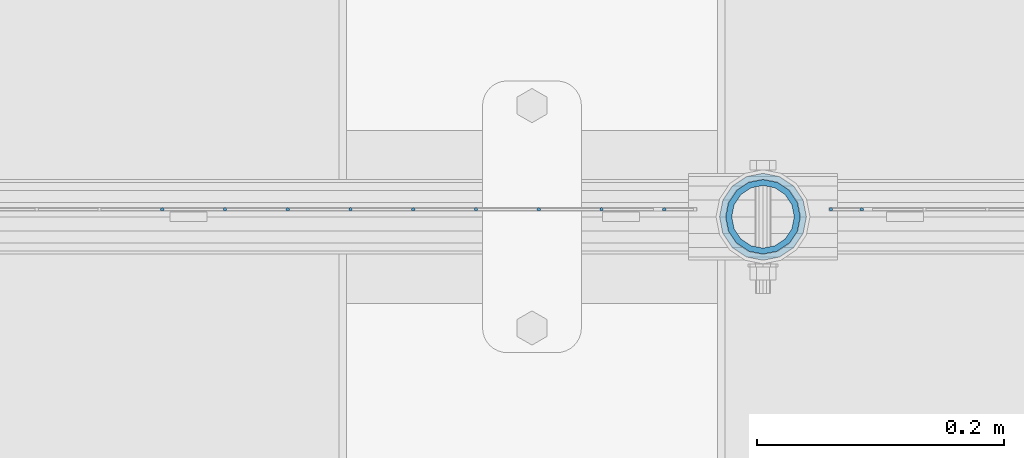
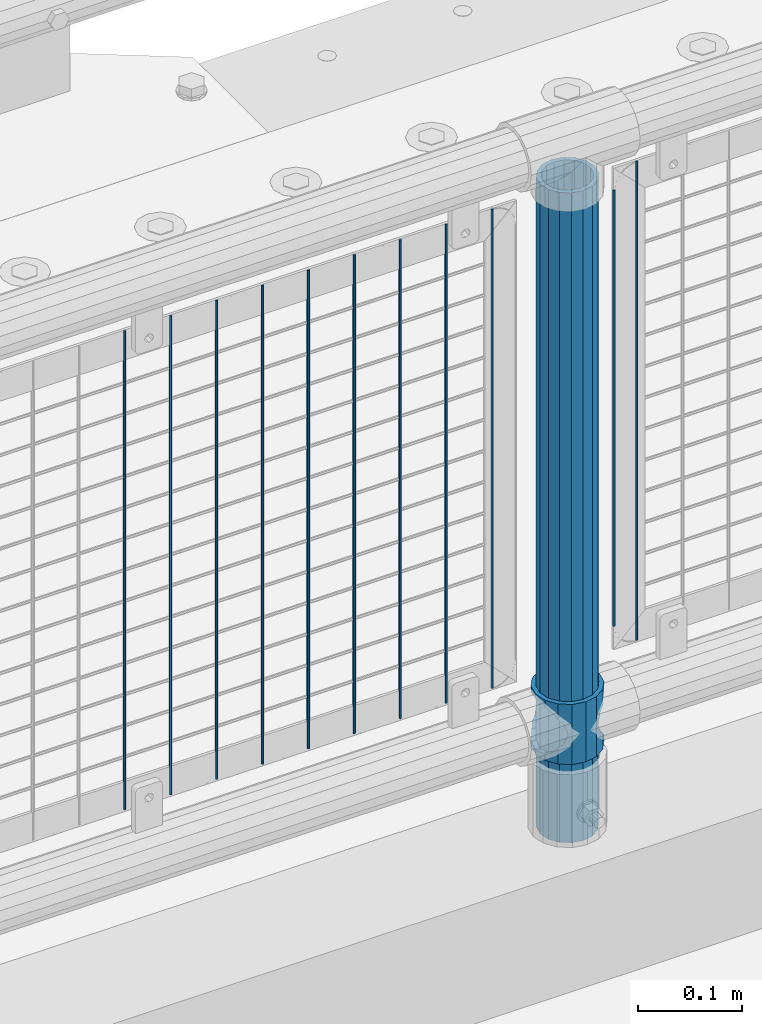
# One storey, part 67 of 242: 13 columns.
"""IFC2X3 building model written with IfcOpenShell, lengths in millimetres."""

from ifc_helpers import new_model, si_unit, frame, origin_with_axes, place, context, subcontext, project, spatial, faceted_brep, material, type_object, element, save


model = new_model("IFC2X3")

# Units and contexts
model_context = context("Model", 3, precision=1e-05, world=origin_with_axes())
body_context = subcontext(model_context, "Body", "Model", "MODEL_VIEW")
ifc_project = project(units=[si_unit("LENGTHUNIT", "METRE", prefix="MILLI"), si_unit("AREAUNIT", "SQUARE_METRE"), si_unit("VOLUMEUNIT", "CUBIC_METRE"), si_unit("MASSUNIT", "GRAM", prefix="KILO"), si_unit("TIMEUNIT", "SECOND"), si_unit("PLANEANGLEUNIT", "RADIAN"), si_unit("SOLIDANGLEUNIT", "STERADIAN"), si_unit("THERMODYNAMICTEMPERATUREUNIT", "DEGREE_CELSIUS"), si_unit("LUMINOUSINTENSITYUNIT", "LUMEN")], contexts=[model_context])

# Site, building, storey
site_placement = place(None, origin_with_axes())
site = spatial("IfcSite", under=ifc_project, at=site_placement, CompositionType="ELEMENT")
building_placement = place(site_placement, origin_with_axes())
building = spatial("IfcBuilding", under=site, at=building_placement, Name="Standard", CompositionType="ELEMENT")
storey_placement = place(building_placement, origin_with_axes())
storey = spatial("IfcBuildingStorey", under=building, at=storey_placement, Name="Undefined", CompositionType="ELEMENT", Elevation=0.0)

# Columns
ifc_material_1 = material()
column_type_1 = type_object("IfcColumnType", PredefinedType="NOTDEFINED")
column_1_placement = place(storey_placement, frame((-38563.0, -19335.5, 168.02), z_axis=(-1.0, 0.0, 0.0), x_axis=(0.0, 0.0, 1.0)))
element("IfcColumn", 1, at=column_1_placement, inside=storey, type_object=column_type_1, material=ifc_material_1, context=body_context, shape_type="Brep", body=[
    faceted_brep([(0.0, -25.3499999999985, 0.0), (0.0, -23.4203461491597, 9.70102501045403), (760.0, -23.4203461491597, 9.70102501045403), (760.0, -25.3499999999985, 0.0), (0.0, -17.9251569030785, 17.9251569030785), (760.0, -17.9251569030785, 17.9251569030785), (0.0, -9.70102501045403, 23.4203461491597), (760.0, -9.70102501045403, 23.4203461491597), (0.0, 0.0, 25.3499999999985), (760.0, 0.0, 25.3499999999985), (0.0, 9.70102501045403, 23.4203461491597), (760.0, 9.70102501045403, 23.4203461491597), (0.0, 17.9251569030785, 17.9251569030785), (760.0, 17.9251569030785, 17.9251569030785), (0.0, 23.4203461491597, 9.70102501045403), (760.0, 23.4203461491597, 9.70102501045403), (0.0, 25.3499999999985, 0.0), (760.0, 25.3499999999985, 0.0), (0.0, 23.4203461491597, -9.70102501045403), (760.0, 23.4203461491597, -9.70102501045403), (0.0, 17.9251569030785, -17.9251569030785), (760.0, 17.9251569030785, -17.9251569030785), (0.0, 9.70102501045403, -23.4203461491597), (760.0, 9.70102501045403, -23.4203461491597), (0.0, 0.0, -25.3499999999985), (760.0, 0.0, -25.3499999999985), (0.0, -9.70102501045403, -23.4203461491597), (760.0, -9.70102501045403, -23.4203461491597), (0.0, -17.9251569030785, -17.9251569030785), (760.0, -17.9251569030785, -17.9251569030785), (0.0, -23.4203461491597, -9.70102501045403), (760.0, -23.4203461491597, -9.70102501045403), (0.0, -30.1500000000015, 0.0), (0.0, -27.8549679052157, -11.5379054858058), (760.0, -27.8549679052157, -11.5379054858058), (760.0, -30.1500000000015, 0.0), (0.0, -21.3192694527752, -21.3192694527752), (760.0, -21.3192694527752, -21.3192694527752), (0.0, -11.5379054858058, -27.8549679052157), (760.0, -11.5379054858058, -27.8549679052157), (0.0, 0.0, -30.1500000000015), (760.0, 0.0, -30.1500000000015), (0.0, 11.5379054858058, -27.8549679052157), (760.0, 11.5379054858058, -27.8549679052157), (0.0, 21.3192694527752, -21.3192694527752), (760.0, 21.3192694527752, -21.3192694527752), (0.0, 27.8549679052157, -11.5379054858058), (760.0, 27.8549679052157, -11.5379054858058), (0.0, 30.1500000000015, 0.0), (760.0, 30.1500000000015, 0.0), (0.0, 27.8549679052157, 11.5379054858058), (760.0, 27.8549679052157, 11.5379054858058), (0.0, 21.3192694527752, 21.3192694527752), (760.0, 21.3192694527752, 21.3192694527752), (0.0, 11.5379054858058, 27.8549679052157), (760.0, 11.5379054858058, 27.8549679052157), (0.0, 0.0, 30.1500000000015), (760.0, 0.0, 30.1500000000015), (0.0, -11.5379054858058, 27.8549679052157), (760.0, -11.5379054858058, 27.8549679052157), (0.0, -21.3192694527752, 21.3192694527752), (760.0, -21.3192694527752, 21.3192694527752), (0.0, -27.8549679052157, 11.5379054858058), (760.0, -27.8549679052157, 11.5379054858058)], [[[0, 1, 2, 3]], [[1, 4, 5, 2]], [[4, 6, 7, 5]], [[6, 8, 9, 7]], [[8, 10, 11, 9]], [[10, 12, 13, 11]], [[12, 14, 15, 13]], [[14, 16, 17, 15]], [[16, 18, 19, 17]], [[18, 20, 21, 19]], [[20, 22, 23, 21]], [[22, 24, 25, 23]], [[24, 26, 27, 25]], [[26, 28, 29, 27]], [[28, 30, 31, 29]], [[30, 0, 3, 31]], [[32, 33, 34, 35]], [[33, 36, 37, 34]], [[36, 38, 39, 37]], [[38, 40, 41, 39]], [[40, 42, 43, 41]], [[42, 44, 45, 43]], [[44, 46, 47, 45]], [[46, 48, 49, 47]], [[48, 50, 51, 49]], [[50, 52, 53, 51]], [[52, 54, 55, 53]], [[54, 56, 57, 55]], [[56, 58, 59, 57]], [[58, 60, 61, 59]], [[60, 62, 63, 61]], [[62, 32, 35, 63]], [[37, 39, 41, 43, 45, 47, 49, 51, 53, 55, 57, 59, 61, 63, 35, 34], [5, 7, 9, 11, 13, 15, 17, 19, 21, 23, 25, 27, 29, 31, 3, 2]], [[62, 60, 58, 56, 54, 52, 50, 48, 46, 44, 42, 40, 38, 36, 33, 32], [30, 28, 26, 24, 22, 20, 18, 16, 14, 12, 10, 8, 6, 4, 1, 0]]]),
])
ifc_material_2 = material(Name="Misc_Undefined")
column_type_2 = type_object("IfcColumnType", PredefinedType="NOTDEFINED")
column_2_placement = place(storey_placement, frame((-38563.0, -19335.5, 263.02), z_axis=(-1.0, 0.0, 0.0), x_axis=(0.0, 0.0, 1.0)))
element("IfcColumn", 2, at=column_2_placement, inside=storey, type_object=column_type_2, material=ifc_material_2, context=body_context, shape_type="Brep", body=[
    faceted_brep([(63.1897438117172, 11.614442172282, -32.8397438117245), (63.1897438117172, 11.614442172282, -28.0397438117143), (56.6106908090114, 21.46069080901, -21.4606908090136), (56.6106908090114, 21.46069080901, -27.1226768591077), (61.9623795176744, 13.4513226476338, -32.4743655677739), (46.7644421722801, 28.0397438117179, -11.6144421722784), (46.7644421722801, 28.0397438117179, -20.0882031229849), (51.5310424080006, 24.8548033587067, -24.8548033587067), (35.1500000000015, 30.35, 0.0), (35.1499999999996, 30.3499999999985, -16.6306603983685), (23.5355578277192, 28.0397438117179, -11.6144421722784), (23.5355578277192, 28.0397438117179, -20.0882031229849), (18.7689575919987, 24.8548033587067, -24.8548033587067), (13.6893091909879, 21.46069080901, -21.4606908090136), (13.6893091909879, 21.46069080901, -27.1226768591077), (8.33762048232262, 13.4513226476338, -32.4743655677739), (7.11025618828211, 11.614442172282, -28.0397438117143), (7.11025618828211, 11.614442172282, -32.8397438117245), (4.79999999999961, 0.0, -30.3499999999985), (4.79999999999961, 0.0, -35.1500000000015), (7.11025618828211, -11.614442172282, -28.0397438117143), (7.11025618828211, -11.614442172282, -32.8397438117172), (13.6893091909879, -21.46069080901, -21.4606908090136), (13.6893091909879, -21.46069080901, -27.1226768591077), (8.33762048232484, -13.4513226476338, -32.4743655677739), (23.5355578277191, -28.0397438117179, -11.6144421722784), (23.5355578277191, -28.0397438117179, -20.0882031229921), (18.7689575919975, -24.8548033587067, -24.8548033587067), (35.1500000000015, -30.35, 0.0), (35.1499999999996, -30.3499999999985, -16.6306603983758), (46.7644421722801, -28.0397438117179, -11.6144421722784), (46.7644421722801, -28.0397438117179, -20.0882031229921), (51.5310424079973, -24.8548033587067, -24.8548033587067), (56.6106908090114, -21.46069080901, -21.4606908090136), (56.6106908090114, -21.46069080901, -27.1226768591077), (61.9623795176767, -13.4513226476338, -32.4743655677739), (63.1897438117172, -11.614442172282, -28.0397438117143), (63.1897438117172, -11.614442172282, -32.8397438117172), (65.4999999999997, 0.0, -30.3499999999985), (65.4999999999997, 0.0, -35.1500000000015), (0.0, -28.0397438117179, -11.6144421722784), (0.0, -30.3499999999985, 0.0), (0.0, -21.46069080901, -21.4606908090136), (0.0, -11.614442172282, -28.0397438117143), (0.0, 0.0, -30.3499999999985), (0.0, 11.614442172282, -28.0397438117143), (0.0, 21.46069080901, -21.4606908090136), (0.0, 28.0397438117179, -11.6144421722784), (0.0, 30.3499999999985, 0.0), (0.0, 28.0397438117179, 11.6144421722784), (23.5355578277192, 28.0397438117179, 11.614442172282), (0.0, 21.46069080901, 21.4606908090136), (13.6893091909879, 21.46069080901, 21.46069080901), (0.0, 11.614442172282, 28.0397438117143), (7.11025618828211, 11.614442172282, 28.0397438117179), (0.0, 0.0, 30.3499999999985), (4.79999999999961, 0.0, 30.3499999999985), (0.0, -11.614442172282, 28.0397438117143), (7.11025618828205, -11.614442172282, 28.0397438117179), (0.0, -21.46069080901, 21.4606908090136), (13.6893091909879, -21.46069080901, 21.46069080901), (0.0, -28.0397438117179, 11.6144421722784), (23.5355578277191, -28.0397438117179, 11.614442172282), (0.0, -32.4743655677703, 13.4513226476338), (0.0, -35.1500000000015, 0.0), (70.2999999999993, -35.1500000000015, 0.0), (70.2999999999993, -32.4743655677703, 13.4513226476338), (0.0, 13.4513226476338, -32.4743655677739), (0.0, 24.8548033587067, -24.8548033587067), (0.0, 0.0, -35.1500000000015), (0.0, -13.4513226476338, -32.4743655677739), (0.0, -24.8548033587067, -24.8548033587067), (0.0, -24.8548033587067, 24.8548033587067), (0.0, -13.4513226476338, 32.4743655677739), (0.0, 0.0, 35.1500000000015), (0.0, 13.4513226476338, 32.4743655677739), (0.0, 24.8548033587067, 24.8548033587067), (0.0, 32.4743655677703, 13.4513226476338), (0.0, 35.1500000000015, 0.0), (0.0, 32.4743655677703, -13.4513226476338), (0.0, -32.4743655677703, -13.4513226476338), (70.2999999999993, 32.4743655677703, 13.4513226476338), (70.2999999999993, 35.1500000000015, 0.0), (70.2999999999993, 32.4743655677703, -13.4513226476338), (70.2999999999993, 24.8548033587067, -24.8548033587067), (70.2999999999993, 13.4513226476338, -32.4743655677739), (70.2999999999993, 0.0, -35.1500000000015), (70.2999999999993, -13.4513226476338, -32.4743655677739), (70.2999999999993, -24.8548033587067, -24.8548033587067), (70.2999999999993, -32.4743655677703, -13.4513226476338), (70.2999999999993, 28.0397438117179, 11.6144421722784), (70.2999999999993, 21.46069080901, 21.4606908090136), (56.6106908090114, 21.46069080901, 21.46069080901), (46.7644421722801, 28.0397438117179, 11.614442172282), (70.2999999999993, 11.614442172282, 28.0397438117143), (63.1897438117172, 11.614442172282, 28.0397438117179), (70.2999999999993, 0.0, 30.3499999999985), (65.4999999999997, 0.0, 30.3499999999985), (70.2999999999993, -11.614442172282, 28.0397438117143), (63.1897438117172, -11.614442172282, 28.0397438117179), (70.2999999999993, -21.46069080901, 21.4606908090136), (56.6106908090114, -21.46069080901, 21.46069080901), (70.2999999999993, -28.0397438117179, 11.6144421722784), (46.7644421722801, -28.0397438117179, 11.614442172282), (70.2999999999993, -11.614442172282, -28.0397438117143), (70.2999999999993, 0.0, -30.3499999999985), (70.2999999999993, -21.46069080901, -21.4606908090136), (70.2999999999993, -28.0397438117179, -11.6144421722784), (70.2999999999993, -30.3499999999985, 0.0), (70.2999999999993, 24.8548033587067, 24.8548033587067), (70.2999999999993, 13.4513226476338, 32.4743655677739), (70.2999999999993, 0.0, 35.1500000000015), (70.2999999999993, -13.4513226476338, 32.4743655677739), (70.2999999999993, -24.8548033587067, 24.8548033587067), (70.2999999999993, 30.3499999999985, 0.0), (70.2999999999993, 28.0397438117179, -11.6144421722784), (70.2999999999993, 21.46069080901, -21.4606908090136), (70.2999999999993, 11.614442172282, -28.0397438117143), (61.9623795176744, 13.4513226476338, 32.4743655677703), (51.5310424080006, 24.8548033587067, 24.8548033587067), (56.6106908090114, 21.46069080901, 27.1226768591077), (65.4999999999997, 0.0, 35.1500000000015), (63.1897438117172, 11.614442172282, 32.8397438117136), (63.1897438117172, -11.614442172282, 32.8397438117172), (61.9623795176767, -13.4513226476338, 32.4743655677703), (56.6106908090114, -21.46069080901, 27.1226768591077), (51.5310424080038, -24.8548033587067, 24.8548033587067), (18.7689575919954, -24.8548033587067, 24.8548033587067), (46.7644421722801, -28.0397438117179, 20.0882031229885), (35.1499999999996, -30.3499999999985, 16.6306603983685), (23.5355578277191, -28.0397438117179, 20.0882031229885), (8.33762048232484, -13.4513226476338, 32.4743655677703), (13.6893091909879, -21.46069080901, 27.1226768591077), (4.79999999999961, 0.0, 35.1500000000015), (7.11025618828205, -11.614442172282, 32.8397438117172), (7.11025618828211, 11.614442172282, 32.8397438117136), (8.33762048232262, 13.4513226476338, 32.4743655677703), (13.6893091909879, 21.46069080901, 27.1226768591077), (18.768957592002, 24.8548033587067, 24.8548033587067), (23.5355578277192, 28.0397438117179, 20.0882031229812), (35.1499999999996, 30.3499999999985, 16.6306603983721), (46.7644421722801, 28.0397438117179, 20.0882031229812)], [[[0, 1, 2, 3, 4]], [[3, 2, 5, 6, 7]], [[6, 5, 8, 9]], [[9, 8, 10, 11]], [[12, 11, 10, 13, 14]], [[15, 14, 13, 16, 17]], [[17, 16, 18, 19]], [[19, 18, 20, 21]], [[21, 20, 22, 23, 24]], [[23, 22, 25, 26, 27]], [[26, 25, 28, 29]], [[29, 28, 30, 31]], [[32, 31, 30, 33, 34]], [[35, 34, 33, 36, 37]], [[37, 36, 38, 39]], [[39, 38, 1, 0]], [[40, 41, 28, 25]], [[42, 40, 25, 22]], [[43, 42, 22, 20]], [[44, 43, 20, 18]], [[45, 44, 18, 16]], [[46, 45, 16, 13]], [[47, 46, 13, 10]], [[48, 47, 10, 8]], [[49, 48, 8, 50]], [[51, 49, 50, 52]], [[53, 51, 52, 54]], [[55, 53, 54, 56]], [[57, 55, 56, 58]], [[59, 57, 58, 60]], [[61, 59, 60, 62]], [[41, 61, 62, 28]], [[63, 64, 65, 66]], [[67, 68, 12, 14, 15]], [[69, 67, 15, 17, 19]], [[24, 70, 69, 19, 21]], [[27, 71, 70, 24, 23]], [[63, 72, 73, 74, 75, 76, 77, 78, 79, 68, 67, 69, 70, 71, 80, 64], [40, 42, 43, 44, 45, 46, 47, 48, 49, 51, 53, 55, 57, 59, 61, 41]], [[78, 77, 81, 82]], [[79, 78, 82, 83]], [[68, 79, 83, 84, 7, 6, 9, 11, 12]], [[7, 84, 85, 4, 3]], [[4, 85, 86, 39, 0]], [[87, 88, 32, 34, 35]], [[86, 87, 35, 37, 39]], [[29, 31, 32, 88, 89, 80, 71, 27, 26]], [[64, 80, 89, 65]], [[90, 91, 92, 93]], [[91, 94, 95, 92]], [[94, 96, 97, 95]], [[96, 98, 99, 97]], [[98, 100, 101, 99]], [[100, 102, 103, 101]], [[104, 105, 38, 36]], [[106, 104, 36, 33]], [[107, 106, 33, 30]], [[108, 107, 30, 28]], [[102, 108, 28, 103]], [[88, 87, 86, 85, 84, 83, 82, 81, 109, 110, 111, 112, 113, 66, 65, 89], [100, 98, 96, 94, 91, 90, 114, 115, 116, 117, 105, 104, 106, 107, 108, 102]], [[118, 110, 109, 119, 120]], [[121, 111, 110, 118, 122]], [[112, 111, 121, 123, 124]], [[113, 112, 124, 125, 126]], [[127, 72, 63, 66, 113, 126, 128, 129, 130]], [[131, 73, 72, 127, 132]], [[133, 74, 73, 131, 134]], [[75, 74, 133, 135, 136]], [[76, 75, 136, 137, 138]], [[119, 109, 81, 77, 76, 138, 139, 140, 141]], [[92, 120, 119, 141, 93]], [[95, 122, 118, 120, 92]], [[97, 121, 122, 95]], [[99, 123, 121, 97]], [[101, 125, 124, 123, 99]], [[103, 128, 126, 125, 101]], [[28, 129, 128, 103]], [[62, 130, 129, 28]], [[60, 132, 127, 130, 62]], [[58, 134, 131, 132, 60]], [[56, 133, 134, 58]], [[54, 135, 133, 56]], [[52, 137, 136, 135, 54]], [[50, 139, 138, 137, 52]], [[8, 140, 139, 50]], [[93, 141, 140, 8]], [[114, 90, 93, 8]], [[115, 114, 8, 5]], [[116, 115, 5, 2]], [[117, 116, 2, 1]], [[105, 117, 1, 38]]]),
])
column_type_3 = type_object("IfcColumnType", Name="D3", PredefinedType="NOTDEFINED")
column_3_placement = place(storey_placement, frame((-38508.0, -19329.5, 378.02), z_axis=(-1.0, 0.0, 0.0), x_axis=(0.0, 0.0, 1.0)))
element("IfcColumn", 3, at=column_3_placement, inside=storey, type_object=column_type_3, material=ifc_material_2, ObjectType="D3", context=body_context, shape_type="Brep", body=[
    faceted_brep([(0.0, -1.50000000000364, 0.0), (-3.63797880709171e-12, -0.750000000003638, -1.29903810567669), (510.0, -0.75, -1.29903810567703), (510.0, -1.5, 0.0), (0.0, 0.749999999996362, -1.29903810567669), (510.0, 0.75, -1.29903810567703), (-3.63797880709171e-12, 1.49999999999636, 0.0), (510.0, 1.5, 0.0), (0.0, 0.749999999996362, 1.29903810567669), (510.0, 0.75, 1.29903810567703), (-3.63797880709171e-12, -0.750000000003638, 1.29903810567669), (510.0, -0.75, 1.29903810567703)], [[[0, 1, 2, 3]], [[1, 4, 5, 2]], [[4, 6, 7, 5]], [[6, 8, 9, 7]], [[8, 10, 11, 9]], [[10, 0, 3, 11]], [[5, 7, 9, 11, 3, 2]], [[10, 8, 6, 4, 1, 0]]]),
])
for number, where, z_axis, x_axis in (
    (4, (-38483.0, -19329.5, 353.02), (-1.0, 0.0, 0.0), (0.0, 0.0, 1.0)),
    (5, (-38693.796, -19329.5, 353.02), (-1.0, 0.0, 0.0), (0.0, 0.0, 1.0)),
    (6, (-38744.589, -19329.5, 353.02), (-1.0, 0.0, 0.0), (0.0, 0.0, 1.0)),
    (7, (-38795.382, -19329.5, 353.02), (-1.0, 0.0, 0.0), (0.0, 0.0, 1.0)),
    (8, (-38846.175, -19329.5, 353.02), (-1.0, 0.0, 0.0), (0.0, 0.0, 1.0)),
    (9, (-38896.968, -19329.5, 353.02), (-1.0, 0.0, 0.0), (0.0, 0.0, 1.0)),
    (10, (-38947.761, -19329.5, 353.02), (-1.0, 0.0, 0.0), (0.0, 0.0, 1.0)),
    (11, (-38998.554, -19329.5, 353.02), (-1.0, 0.0, 0.0), (0.0, 0.0, 1.0)),
    (12, (-38643.003, -19329.5, 353.02), (-1.0, 0.0, 0.0), (0.0, 0.0, 1.0)),
    (13, (-39049.347, -19329.5, 353.02), (-1.0, 0.0, 0.0), (0.0, 0.0, 1.0)),
):
    element("IfcColumn", number, at=place(storey_placement, frame(where, z_axis=z_axis, x_axis=x_axis)), inside=storey, type_object=column_type_3, material=ifc_material_2, ObjectType="D3", context=body_context, shape_type="Brep", body=[
        faceted_brep([(0.0, -1.50000000000364, 0.0), (-3.63797880709171e-12, -0.750000000003638, -1.29903810567669), (560.0, -0.75, -1.29903810567703), (560.0, -1.5, 0.0), (0.0, 0.749999999996362, -1.29903810567669), (560.0, 0.75, -1.29903810567703), (-3.63797880709171e-12, 1.49999999999636, 0.0), (560.0, 1.5, 0.0), (0.0, 0.749999999996362, 1.29903810567669), (560.0, 0.75, 1.29903810567703), (-3.63797880709171e-12, -0.750000000003638, 1.29903810567669), (560.0, -0.75, 1.29903810567703)], [[[0, 1, 2, 3]], [[1, 4, 5, 2]], [[4, 6, 7, 5]], [[6, 8, 9, 7]], [[8, 10, 11, 9]], [[10, 0, 3, 11]], [[5, 7, 9, 11, 3, 2]], [[10, 8, 6, 4, 1, 0]]]),
    ])

save(model, "model.ifc")
